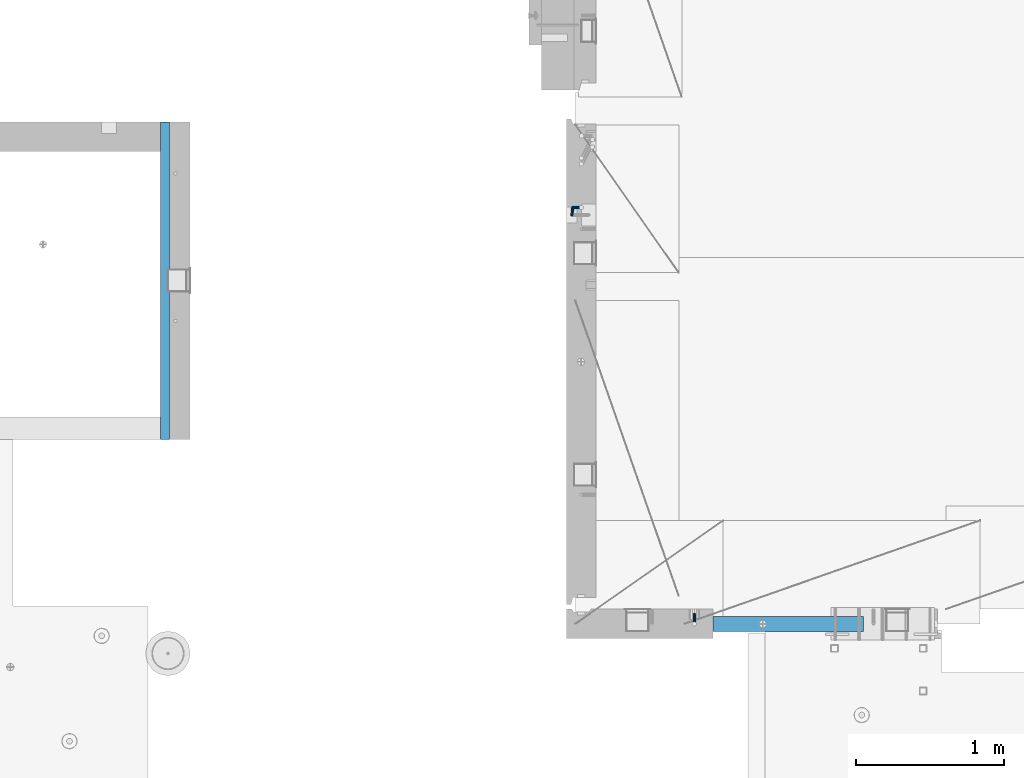
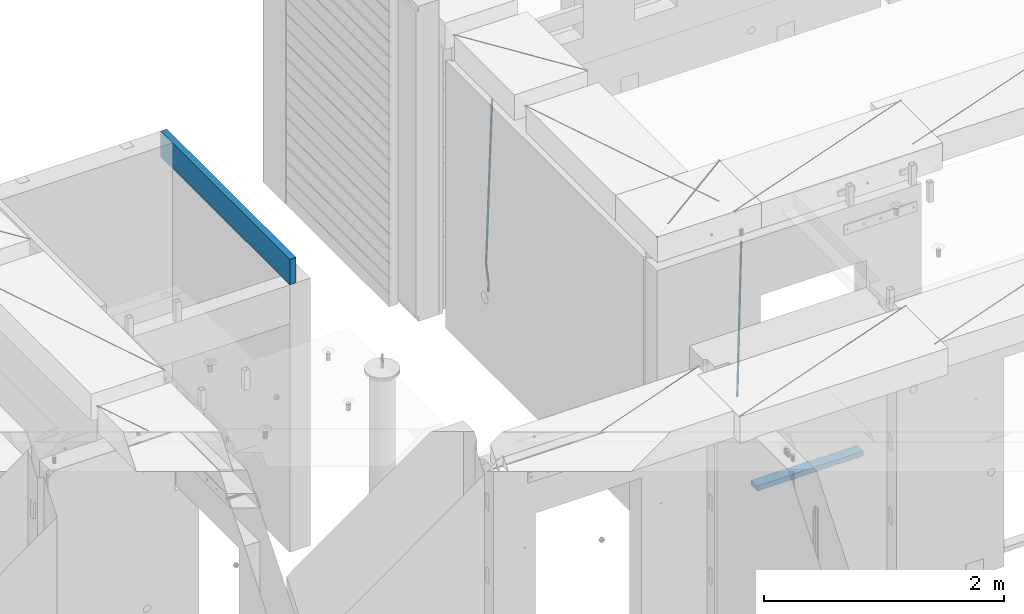
# One storey, part 102 of 309: 4 beams, 3 elements without a shape of their own.
"""IFC2X3 building model written with IfcOpenShell, lengths in millimetres."""

from ifc_helpers import new_model, si_unit, frame, origin_with_axes, place, context, subcontext, project, spatial, faceted_brep, material, type_object, element, aggregate, save


model = new_model("IFC2X3")

# Units and contexts
model_context = context("Model", 3, precision=1e-05, world=origin_with_axes())
body_context = subcontext(model_context, "Body", "Model", "MODEL_VIEW")
ifc_project = project(units=[si_unit("LENGTHUNIT", "METRE", prefix="MILLI"), si_unit("AREAUNIT", "SQUARE_METRE"), si_unit("VOLUMEUNIT", "CUBIC_METRE"), si_unit("MASSUNIT", "GRAM", prefix="KILO"), si_unit("TIMEUNIT", "SECOND"), si_unit("PLANEANGLEUNIT", "RADIAN"), si_unit("SOLIDANGLEUNIT", "STERADIAN"), si_unit("THERMODYNAMICTEMPERATUREUNIT", "DEGREE_CELSIUS"), si_unit("LUMINOUSINTENSITYUNIT", "LUMEN")], contexts=[model_context])

# Site, building, storey
site_placement = place(None, origin_with_axes())
site = spatial("IfcSite", under=ifc_project, at=site_placement, CompositionType="ELEMENT")
building_placement = place(site_placement, origin_with_axes())
building = spatial("IfcBuilding", under=site, at=building_placement, CompositionType="ELEMENT")
storey_placement = place(building_placement, origin_with_axes())
storey = spatial("IfcBuildingStorey", under=building, at=storey_placement, Name="7", CompositionType="ELEMENT", Elevation=0.0)

# Assembly, beam
assembly_1_placement = place(storey_placement, origin_with_axes())
assembly_1 = element("IfcElementAssembly", 1, at=assembly_1_placement, inside=storey, Name="W1", AssemblyPlace="NOTDEFINED", PredefinedType="REINFORCEMENT_UNIT")
ifc_material_1 = material()
beam_type_1 = type_object("IfcBeamType", Name="D20", PredefinedType="NOTDEFINED")
beam_1_placement = place(assembly_1_placement, frame((22244.9999977209, 19749.9999999961, 100510.0), z_axis=(0.999839490204639, 0.000205763000043867, -0.0179151190036643), x_axis=(0.0179151190067552, -2.89999975377855e-08, 0.999839511377188)))
beam_1 = element("IfcBeam", 2, at=beam_1_placement, type_object=beam_type_1, material=ifc_material_1, Name="JM20", ObjectType="D20", context=body_context, shape_type="Brep", body=[
    faceted_brep([(0.0, -10.0, 0.0), (-4.19531716033816e-08, -7.07106781186667, -7.07106781187031), (89.0110247484263, -7.07106781240145, -7.07106781090988), (89.0110247510165, -10.0000000005348, 9.56788426265121e-10), (0.0, 0.0, -10.0), (89.011024747364, -5.3114490583539e-10, -9.99999999903957), (4.196772351861e-08, 7.07106781186303, -7.07106781186667), (89.011024748499, 7.07106781132825, -7.07106781090988), (0.0, 10.0, 0.0), (89.0110247511475, 9.99999999946522, 9.60426405072212e-10), (4.196772351861e-08, 7.07106781185939, 7.07106781185939), (89.0110247537523, 7.07106781133189, 7.07106781282346), (0.0, 0.0, 10.0), (89.0110247548, -5.38420863449574e-10, 10.0000000009604), (-4.19531716033816e-08, -7.07106781187031, 7.07106781185939), (89.011024753665, -7.07106781240145, 7.07106781282346), (89.976954074853, -7.07106781240873, -7.07106781089533), (89.5110247510311, -10.0000000005384, 9.64064383879304e-10), (91.0331505986251, -5.45696821063757e-10, -9.99999999902502), (92.0609087232588, 7.0710678113137, -7.0710678108735), (92.4581816781865, 9.99999999944339, 9.96806193143129e-10), (91.9922523543646, 7.0710678113137, 7.0710678128562), (90.9360558305925, -5.49334799870849e-10, 10.0000000009786), (89.9082977059443, -7.07106781240509, 7.07106781283073), (90.9017822964088, -7.34968577266045, -7.06188867690798), (89.9897493307071, -10.1442227467705, 0.00475145313612302), (92.9692332949489, -0.583273087540874, -9.98078393048854), (94.9810175709281, 6.19134252624281, -7.04208505521092), (95.7586591800355, 9.00568312201358, 0.0327580035191204), (94.8466262143338, 6.21114614789622, 7.09939813356323), (92.7791752157791, -0.555266537216085, 10.0182933871438), (90.7673909398, -7.3298821510034, 7.07959451186616), (253.08880553169, -56.210886739078, -5.45214496144763), (252.176772565959, -59.0054237131953, 1.61449516859284), (255.15625653023, -49.4444740539693, -8.37104021503183), (257.168040806209, -42.6698584401747, -5.43234133975056), (257.945682415317, -39.8555178444112, 1.64250171897947), (257.033649449615, -42.6500548185213, 8.70914184901994), (254.966198451046, -49.4164675036409, 11.6280371026041), (252.954414175081, -56.1910831174246, 8.68933822732652), (256.040808205085, -57.1002205032819, -5.4228456521887), (255.476727913934, -59.9995832841632, 1.64724798862153), (257.137813126028, -50.0414468149283, -8.35137280753406), (258.125132072062, -42.9581961120275, -5.42284198758716), (258.424406994978, -39.9997405906397, 1.6472531711479), (257.860326703827, -42.8991033715283, 8.71734681195812), (256.763321782899, -49.9578770598782, 11.6458739673035), (255.77600283685, -57.0411277627827, 8.71734314736023), (259.122763950654, -57.1002024144545, -5.33542963766376), (258.921953907935, -59.9995630632038, 1.74496773231294), (259.206601813319, -50.0414346726539, -8.2926940733596), (259.124356413013, -42.958190247311, -5.39450017585841), (258.924205989781, -39.9997376571882, 1.66142937606492), (258.723395947076, -42.8990983059412, 8.74182674604526), (258.639558084411, -49.9578660477418, 11.6990911817338), (258.721803484717, -57.0411104730847, 8.80089728423263), (379.553966330364, -57.0994955712195, -1.91954160900059), (379.353156287645, -59.9988562199724, 5.16085576097976), (379.637804193029, -50.0407278294188, -4.87680604468915), (379.555558792737, -42.9574834040832, -1.9786121471916), (379.355408369505, -39.9990308139568, 5.07731740473173), (379.154598326786, -42.8983914627097, 12.1577147747084), (379.070760464136, -49.9571592045104, 15.1149792104006), (379.153005864428, -57.0404036298532, 12.2167853129031), (380.071125123432, -57.0994925358791, -1.90487301402027), (379.911895631682, -59.9988529405782, 5.17670373889996), (380.137603187861, -50.0407248959636, -4.86262983977576), (380.07238787644, -42.957480370671, -1.96395290403234), (379.913681434104, -39.9990275372984, 5.09315215719107), (379.754451942368, -42.8983879420121, 12.1747289101186), (379.687973877939, -49.9571555819202, 15.1324857358704), (379.75318918936, -57.0404001072166, 12.2338088001234), (380.588420535452, -57.0994907600943, -1.89627990118606), (380.470782579127, -59.9988510220282, 5.18598775436112), (380.637534215668, -50.0407231797944, -4.85432517742447), (380.589353492032, -42.9574785960249, -1.95536526964497), (380.472101978958, -39.9990256203491, 5.10242842495063), (380.354464022632, -42.898385882283, 12.1846960805015), (380.305350342416, -49.9571534625793, 15.1427413567362), (380.353531066052, -57.0403980463561, 12.2437814489567), (1774.34333976687, -57.0947062606101, 21.2562418682064), (1774.22570181053, -59.994066522544, 28.3385095237536), (1774.39245344709, -50.0359386803066, 18.298196591968), (1774.34427272342, -42.952694096537, 21.1971564997511), (1774.22702121038, -39.9942411208649, 28.2549501943431), (1774.10938325404, -42.8936013827915, 35.3372178498939), (1774.06026957383, -49.9523689630987, 38.2952631261323), (1774.10845029748, -57.0356135468646, 35.3963032183528), (1774.88184095189, -57.0947044120367, 21.265187243207), (1774.72579033222, -59.9940648058328, 28.3468168023355), (1774.9851208477, -50.0359366457924, 18.3080417553501), (1774.97513005743, -42.952691930921, 21.2076360596475), (1774.85772105052, -39.9942389557873, 28.2654271380125), (1774.70167043086, -42.8935993495834, 35.3470566971446), (1774.59839053503, -49.9523671158277, 38.3042021849978), (1774.60838132531, -57.0356118306954, 35.4046078807005), (1775.42023891953, -57.1017252492275, 21.2770986786563), (1775.22578299929, -60.0005848287947, 28.3578785647078), (1775.57767464862, -50.0436636878912, 18.3211513262904), (1775.60586647167, -42.9609168833595, 21.2215903769684), (1775.48830000107, -40.0024618548559, 28.2793779716303), (1775.29384408084, -42.9013214344195, 35.3601578576818), (1775.13640835174, -49.9593829957594, 38.3161052100477), (1775.10821652869, -57.0421298002984, 35.4156661593697), (1797.25780408196, -57.3864922781577, 21.7602296774785), (1797.06334816174, -60.2853518577213, 28.841009563519), (1797.41523981106, -50.3284307168215, 18.8042823251126), (1797.44343163411, -43.2456839122824, 21.7047213757796), (1797.32586516351, -40.2872288837862, 28.7625089704488), (1797.13140924327, -43.1860884633497, 35.8432888564967), (1796.97397351419, -50.244150024686, 38.7992362088589), (1796.94578169113, -57.3268968292286, 35.8987971581882), (1797.8933907514, -57.394780479066, 21.7742913011098), (1797.72334564425, -60.2939583814259, 28.8556112483093), (1797.9938047452, -50.3359753407822, 18.8170824084737), (1797.96576646989, -43.2524952824278, 21.7162774329299), (1797.82570036691, -40.2937468533892, 28.7735672491181), (1797.65565525973, -43.1929247557455, 35.8548871963139), (1797.55524126595, -50.2517298940293, 38.8120960889537), (1797.58327954126, -57.3352099523836, 35.9129010644974), (1798.52903302865, -57.3928987848594, 21.7881546696226), (1798.38340069888, -60.291988491208, 28.8700127493285), (1798.57242062438, -50.3342702388327, 18.8296881194801), (1798.48814762091, -43.2509517236358, 21.7276426801363), (1798.32558000075, -40.2922551588599, 28.7844358731018), (1798.17994767097, -43.1913448652049, 35.8662939528003), (1798.13656007525, -50.2499734112316, 38.8247605029428), (1798.22083307871, -57.3332919264358, 35.9268059422866), (1898.53449695595, -57.0944531984715, 23.9668554182972), (1898.38886462618, -59.9935429048164, 31.0487134979994), (1898.57788455166, -50.0358246524411, 21.0083888681547), (1898.49361154821, -42.9525061372478, 23.9063434288073), (1898.33104392805, -39.9938095724719, 30.9631366217764), (1898.18541159826, -42.8928992788169, 38.0449947014749), (1898.14202400253, -49.95152782484, 41.0034612516174), (1898.22629700601, -57.0348463400442, 38.1055066909612)], [[[0, 1, 2, 3]], [[1, 4, 5, 2]], [[4, 6, 7, 5]], [[6, 8, 9, 7]], [[8, 10, 11, 9]], [[10, 12, 13, 11]], [[12, 14, 15, 13]], [[14, 0, 3, 15]], [[14, 12, 10, 8, 6, 4, 1, 0]], [[3, 2, 16, 17]], [[2, 5, 18, 16]], [[5, 7, 19, 18]], [[7, 9, 20, 19]], [[9, 11, 21, 20]], [[11, 13, 22, 21]], [[13, 15, 23, 22]], [[15, 3, 17, 23]], [[17, 16, 24, 25]], [[16, 18, 26, 24]], [[18, 19, 27, 26]], [[19, 20, 28, 27]], [[20, 21, 29, 28]], [[21, 22, 30, 29]], [[22, 23, 31, 30]], [[23, 17, 25, 31]], [[25, 24, 32, 33]], [[24, 26, 34, 32]], [[26, 27, 35, 34]], [[27, 28, 36, 35]], [[28, 29, 37, 36]], [[29, 30, 38, 37]], [[30, 31, 39, 38]], [[31, 25, 33, 39]], [[33, 32, 40, 41]], [[32, 34, 42, 40]], [[34, 35, 43, 42]], [[35, 36, 44, 43]], [[36, 37, 45, 44]], [[37, 38, 46, 45]], [[38, 39, 47, 46]], [[39, 33, 41, 47]], [[41, 40, 48, 49]], [[40, 42, 50, 48]], [[42, 43, 51, 50]], [[43, 44, 52, 51]], [[44, 45, 53, 52]], [[45, 46, 54, 53]], [[46, 47, 55, 54]], [[47, 41, 49, 55]], [[49, 48, 56, 57]], [[48, 50, 58, 56]], [[50, 51, 59, 58]], [[51, 52, 60, 59]], [[52, 53, 61, 60]], [[53, 54, 62, 61]], [[54, 55, 63, 62]], [[55, 49, 57, 63]], [[57, 56, 64, 65]], [[56, 58, 66, 64]], [[58, 59, 67, 66]], [[59, 60, 68, 67]], [[60, 61, 69, 68]], [[61, 62, 70, 69]], [[62, 63, 71, 70]], [[63, 57, 65, 71]], [[65, 64, 72, 73]], [[64, 66, 74, 72]], [[66, 67, 75, 74]], [[67, 68, 76, 75]], [[68, 69, 77, 76]], [[69, 70, 78, 77]], [[70, 71, 79, 78]], [[71, 65, 73, 79]], [[73, 72, 80, 81]], [[72, 74, 82, 80]], [[74, 75, 83, 82]], [[75, 76, 84, 83]], [[76, 77, 85, 84]], [[77, 78, 86, 85]], [[78, 79, 87, 86]], [[79, 73, 81, 87]], [[81, 80, 88, 89]], [[80, 82, 90, 88]], [[82, 83, 91, 90]], [[83, 84, 92, 91]], [[84, 85, 93, 92]], [[85, 86, 94, 93]], [[86, 87, 95, 94]], [[87, 81, 89, 95]], [[89, 88, 96, 97]], [[88, 90, 98, 96]], [[90, 91, 99, 98]], [[91, 92, 100, 99]], [[92, 93, 101, 100]], [[93, 94, 102, 101]], [[94, 95, 103, 102]], [[95, 89, 97, 103]], [[97, 96, 104, 105]], [[96, 98, 106, 104]], [[98, 99, 107, 106]], [[99, 100, 108, 107]], [[100, 101, 109, 108]], [[101, 102, 110, 109]], [[102, 103, 111, 110]], [[103, 97, 105, 111]], [[105, 104, 112, 113]], [[104, 106, 114, 112]], [[106, 107, 115, 114]], [[107, 108, 116, 115]], [[108, 109, 117, 116]], [[109, 110, 118, 117]], [[110, 111, 119, 118]], [[111, 105, 113, 119]], [[113, 112, 120, 121]], [[112, 114, 122, 120]], [[114, 115, 123, 122]], [[115, 116, 124, 123]], [[116, 117, 125, 124]], [[117, 118, 126, 125]], [[118, 119, 127, 126]], [[119, 113, 121, 127]], [[121, 120, 128, 129]], [[120, 122, 130, 128]], [[122, 123, 131, 130]], [[123, 124, 132, 131]], [[124, 125, 133, 132]], [[125, 126, 134, 133]], [[126, 127, 135, 134]], [[127, 121, 129, 135]], [[130, 131, 132, 133, 134, 135, 129, 128]]]),
])
aggregate(assembly_1, [beam_1])

assembly_2_placement = place(storey_placement, origin_with_axes())
assembly_2 = element("IfcElementAssembly", 3, at=assembly_2_placement, inside=storey, AssemblyPlace="NOTDEFINED", PredefinedType="REINFORCEMENT_UNIT")
beam_2_placement = place(assembly_2_placement, frame((23075.0006866416, 17045.0000022791, 100790.0), z_axis=(0.00020576299992186, -0.999642804629538, -0.0267249099901004), x_axis=(-4.30000201928125e-08, -0.0267249099948059, 0.999642825806181)))
beam_2 = element("IfcBeam", 4, at=beam_2_placement, type_object=beam_type_1, material=ifc_material_1, Name="JM20", ObjectType="D20", context=body_context, shape_type="Brep", body=[
    faceted_brep([(0.0, -10.0, 0.0), (-4.19531716033816e-08, -7.07106781186667, -7.07106781187031), (60.4266690400545, -7.0710677960451, -7.07106780570757), (60.4266690441291, -9.99999998418934, 6.15546014159918e-09), (0.0, 0.0, -10.0), (60.426669036824, 1.58106558956206e-08, -9.99999999384454), (4.196772351861e-08, 7.07106781186303, -7.07106781186667), (60.4266690363438, 7.07106782768096, -7.07106780570757), (0.0, 10.0, 0.0), (60.4266690388904, 10.0000000158179, 6.15182216279209e-09), (4.196772351861e-08, 7.07106781185939, 7.07106781185939), (60.4266690429649, 7.07106782768096, 7.07106781802577), (0.0, 0.0, 10.0), (60.4266690461809, 1.58179318532348e-08, 10.0000000061555), (-4.19531716033816e-08, -7.07106781187031, 7.07106781185939), (60.4266690466611, -7.07106779605238, 7.07106781802213), (61.0378400410118, -7.07106779588503, -7.07106780564936), (60.991799419251, -9.99999998403655, 6.21366780251265e-09), (61.0569027789461, 1.5985278878361e-08, -9.99999999378269), (61.0378209396877, 7.07106782784831, -7.07106780564936), (60.9917724058905, 10.0000000159635, 6.21366780251265e-09), (60.9457317841297, 7.07106782781193, 7.0710678180767), (60.9266690461809, 1.59488990902901e-08, 10.0000000062028), (60.9457508854539, -7.07106779591413, 7.0710678180767), (61.6489592143771, -7.07106614513759, -7.06310863441468), (61.5568818710308, -9.9999984576425, 0.00735959856683621), (61.6870830769039, 1.71821739058942e-06, -9.99179257185824), (61.6489210170112, 7.07106947854481, -7.06310888312146), (61.556827851804, 10.0000015422847, 0.00735924683976918), (61.4647505084577, 7.07106922979438, 7.07782747982128), (61.4266266459163, 1.36643211590126e-06, 10.0065114172685), (61.464788705809, -7.07106639389531, 7.07782772852806), (176.543135720174, -7.07075579406956, -5.56673531796696), (176.451058376813, -9.99968810657447, 1.50373291501455), (176.581259582701, 0.000312069292704109, -8.49541925541052), (176.543097522794, 7.07137982961285, -5.56673556667374), (176.451004357587, 10.00031189336, 1.50373256329476), (176.35892701424, 7.07137958085514, 8.57420079627263), (176.320803151699, 0.000311717507429421, 11.5028847337162), (176.358965211621, -7.07075604281999, 8.57420104497578), (177.098753836006, -7.07075429323595, -5.55949898843028), (176.98362511232, -9.99968666800123, 1.510669025065), (177.146421932586, 0.000313595905026887, -8.48805862247536), (177.098706077581, 7.07138133041735, -5.55949936166144), (176.983557571715, 10.0003133318824, 1.51066849724157), (176.868428848029, 7.07138095712435, 8.58083651073321), (176.820760751449, 0.000313067976094317, 11.5093961447819), (176.868476606425, -7.07075466652896, 8.58083688396073), (177.654312950661, -7.07075204110879, -5.54863964998367), (177.516135294456, -9.99968450931192, 1.52107783331303), (177.711524267797, 0.000315886711177882, -8.47701274570863), (177.654255632195, 7.07138358250813, -5.54864021007961), (177.516054233929, 10.0003154905207, 1.5210770412159), (177.377876577739, 7.0713830223176, 8.59079452451624), (177.320665260588, 0.000315094497636892, 11.5191676202448), (177.377933896176, -7.07075260129932, 8.59079508461218), (299.580241614967, -7.07025777803938, -3.16539205229128), (299.442063958748, -9.99919024624614, 3.90432543100542), (299.637452932104, 0.000810149780591019, -6.09376514801625), (299.58018429653, 7.07187784557391, -3.16539261238358), (299.441982898265, 10.0008097535901, 3.90432463891557), (299.303805242045, 7.07187728538338, 10.974042122205), (299.246593924894, 0.00080935756341205, 13.9024152179336), (299.303862560482, -7.07025833822991, 10.9740426822973), (300.088882651282, -7.07025571611666, -3.15544980669438), (299.971788958996, -9.99918809853989, 3.91467979818117), (300.137357441272, 0.000812176291219657, -6.0839936725497), (300.088834180511, 7.07187990754028, -3.15545019384081), (299.971753863239, 10.0008119014747, 3.91467990454839), (299.854660170953, 7.07187951844026, 10.9848095094276), (299.806185380992, 0.000811626032373169, 13.9133533752902), (299.854708641738, -7.07025610520941, 10.9848098965813), (300.597573977022, -7.07025429077839, -3.14854421417112), (300.501599787152, -9.99918661431002, 3.92187219230618), (300.637311376035, 0.00081357714952901, -6.07720669196715), (300.597534354776, 7.07188133290401, -3.14854448120241), (300.501543752835, 10.0008133856099, 3.92187181466215), (300.40556956298, 7.07188106207104, 10.9922882211395), (300.365832163967, 0.000813194146758178, 13.9209506989318), (300.405609185211, -7.07025456160045, 10.9922884881707), (1494.60304651056, -7.06690872122999, 13.060333041718), (1494.50707232069, -9.99584104476162, 20.1307494481916), (1494.64278390956, 0.00415914670156781, 10.1316705639183), (1494.6030068883, 7.07522690244878, 13.0603327746867), (1494.50701628637, 10.004158955162, 20.1307490705476), (1494.4110420965, 7.07522663162308, 27.2011654770249), (1494.3713046975, 0.00415876370243495, 30.1298279548209), (1494.41108171875, -7.06690899205205, 27.2011657440526), (1495.1211563645, -7.06690726950183, 13.067366492749), (1495.00702625545, -9.99583964390331, 20.1375364287742), (1495.20660775043, 0.00416072652296862, 10.1393245920117), (1495.21332415029, 7.07522861253892, 13.0686179608165), (1495.13737118813, 10.0041607213934, 20.1393062718889), (1495.02324107911, 7.07522834699193, 27.2094762079141), (1494.93778969315, 0.00416035097441636, 30.1375181086514), (1494.93107329329, -7.06690753504881, 27.2082247398503), (1495.63922435709, -7.07365070849846, 13.0742491942874), (1495.5069397148, -10.00235861486, 20.1441724282631), (1495.77038591086, -0.00317370150150964, 10.1468279224828), (1495.82359171678, 7.06728286786529, 13.0767522910828), (1495.76767453534, 9.99594143344802, 20.1477123416917), (1495.63538989302, 7.0672335270865, 27.2176355756565), (1495.50422833927, -0.00324347991045215, 30.1450568474684), (1495.45102253335, -7.07370004928453, 27.2151324788683), (1517.48046966468, -7.35846502584536, 13.3649345949125), (1517.34818502239, -10.2871729322142, 20.4348578288809), (1517.61163121845, -0.287988018848409, 10.4375133231042), (1517.66483702436, 6.78246855052203, 13.3674376917079), (1517.60891984291, 9.71112711610476, 20.4383977423167), (1517.47663520063, 6.78241920973232, 27.5083209762815), (1517.34547364687, -0.288057797257352, 30.4357422480862), (1517.29226784095, -7.35851436663143, 27.5058178794898), (1518.11590717161, -7.36675126123009, 13.3733916404526), (1518.00827439407, -10.295780632965, 20.4436429663911), (1518.18994308249, -0.295529324139352, 10.4452100827657), (1518.18701289421, 6.77565927010801, 13.3743873367348), (1518.10883307132, 9.70460814510079, 20.4450510935785), (1518.00120029377, 6.77557877335857, 27.515302419517), (1517.9271643829, -0.295643163732166, 30.4434839772002), (1517.93009457119, -7.36683175797953, 27.5143067232275), (1518.75139849893, -7.36487536471395, 13.3816537936873), (1518.66841952164, -10.2938120781764, 20.4522328350286), (1518.76830418318, -0.293831718903675, 10.452712053142), (1518.7092334538, 6.77719739167878, 13.3811419616068), (1518.60878914295, 9.7060990139762, 20.4515089951637), (1518.52581016565, 6.77716230052101, 27.522088036505), (1518.50890448141, -0.293881345296541, 30.4510297770539), (1518.56797521077, -7.36491045587172, 27.5225998685855), (1618.77218426704, -7.06661321754655, 14.6790318180938), (1618.68920528975, -9.99554993101265, 21.7496108594387), (1618.78908995127, 0.0044304282637313, 11.7500900775485), (1618.73001922191, 7.07545953884255, 14.6785199860096), (1618.62957491104, 10.0043611611436, 21.748887019563), (1618.54659593375, 7.07542444768478, 28.8194660609042), (1618.52969024952, 0.00438080187086598, 31.7484078014531), (1618.58876097888, -7.06664830870795, 28.819977892992)], [[[0, 1, 2, 3]], [[1, 4, 5, 2]], [[4, 6, 7, 5]], [[6, 8, 9, 7]], [[8, 10, 11, 9]], [[10, 12, 13, 11]], [[12, 14, 15, 13]], [[14, 0, 3, 15]], [[14, 12, 10, 8, 6, 4, 1, 0]], [[3, 2, 16, 17]], [[2, 5, 18, 16]], [[5, 7, 19, 18]], [[7, 9, 20, 19]], [[9, 11, 21, 20]], [[11, 13, 22, 21]], [[13, 15, 23, 22]], [[15, 3, 17, 23]], [[17, 16, 24, 25]], [[16, 18, 26, 24]], [[18, 19, 27, 26]], [[19, 20, 28, 27]], [[20, 21, 29, 28]], [[21, 22, 30, 29]], [[22, 23, 31, 30]], [[23, 17, 25, 31]], [[25, 24, 32, 33]], [[24, 26, 34, 32]], [[26, 27, 35, 34]], [[27, 28, 36, 35]], [[28, 29, 37, 36]], [[29, 30, 38, 37]], [[30, 31, 39, 38]], [[31, 25, 33, 39]], [[33, 32, 40, 41]], [[32, 34, 42, 40]], [[34, 35, 43, 42]], [[35, 36, 44, 43]], [[36, 37, 45, 44]], [[37, 38, 46, 45]], [[38, 39, 47, 46]], [[39, 33, 41, 47]], [[41, 40, 48, 49]], [[40, 42, 50, 48]], [[42, 43, 51, 50]], [[43, 44, 52, 51]], [[44, 45, 53, 52]], [[45, 46, 54, 53]], [[46, 47, 55, 54]], [[47, 41, 49, 55]], [[49, 48, 56, 57]], [[48, 50, 58, 56]], [[50, 51, 59, 58]], [[51, 52, 60, 59]], [[52, 53, 61, 60]], [[53, 54, 62, 61]], [[54, 55, 63, 62]], [[55, 49, 57, 63]], [[57, 56, 64, 65]], [[56, 58, 66, 64]], [[58, 59, 67, 66]], [[59, 60, 68, 67]], [[60, 61, 69, 68]], [[61, 62, 70, 69]], [[62, 63, 71, 70]], [[63, 57, 65, 71]], [[65, 64, 72, 73]], [[64, 66, 74, 72]], [[66, 67, 75, 74]], [[67, 68, 76, 75]], [[68, 69, 77, 76]], [[69, 70, 78, 77]], [[70, 71, 79, 78]], [[71, 65, 73, 79]], [[73, 72, 80, 81]], [[72, 74, 82, 80]], [[74, 75, 83, 82]], [[75, 76, 84, 83]], [[76, 77, 85, 84]], [[77, 78, 86, 85]], [[78, 79, 87, 86]], [[79, 73, 81, 87]], [[81, 80, 88, 89]], [[80, 82, 90, 88]], [[82, 83, 91, 90]], [[83, 84, 92, 91]], [[84, 85, 93, 92]], [[85, 86, 94, 93]], [[86, 87, 95, 94]], [[87, 81, 89, 95]], [[89, 88, 96, 97]], [[88, 90, 98, 96]], [[90, 91, 99, 98]], [[91, 92, 100, 99]], [[92, 93, 101, 100]], [[93, 94, 102, 101]], [[94, 95, 103, 102]], [[95, 89, 97, 103]], [[97, 96, 104, 105]], [[96, 98, 106, 104]], [[98, 99, 107, 106]], [[99, 100, 108, 107]], [[100, 101, 109, 108]], [[101, 102, 110, 109]], [[102, 103, 111, 110]], [[103, 97, 105, 111]], [[105, 104, 112, 113]], [[104, 106, 114, 112]], [[106, 107, 115, 114]], [[107, 108, 116, 115]], [[108, 109, 117, 116]], [[109, 110, 118, 117]], [[110, 111, 119, 118]], [[111, 105, 113, 119]], [[113, 112, 120, 121]], [[112, 114, 122, 120]], [[114, 115, 123, 122]], [[115, 116, 124, 123]], [[116, 117, 125, 124]], [[117, 118, 126, 125]], [[118, 119, 127, 126]], [[119, 113, 121, 127]], [[121, 120, 128, 129]], [[120, 122, 130, 128]], [[122, 123, 131, 130]], [[123, 124, 132, 131]], [[124, 125, 133, 132]], [[125, 126, 134, 133]], [[126, 127, 135, 134]], [[127, 121, 129, 135]], [[130, 131, 132, 133, 134, 135, 129, 128]]]),
])

assembly_3_placement = place(storey_placement, origin_with_axes())
assembly_3 = element("IfcElementAssembly", 5, at=assembly_3_placement, inside=storey, AssemblyPlace="NOTDEFINED", PredefinedType="REINFORCEMENT_UNIT")
ifc_material_2 = material(Name="CONCRETE/C25/30")
beam_type_2 = type_object("IfcBeamType", Name="260X60", PredefinedType="NOTDEFINED")
beam_3_placement = place(assembly_3_placement, frame((19489.999681647, 20380.0, 102600.0), z_axis=(0.0, 0.0, 1.0), x_axis=(0.0, -1.0, 0.0)))
beam_3 = element("IfcBeam", 6, at=beam_3_placement, type_object=beam_type_2, material=ifc_material_2, ObjectType="260X60", context=body_context, shape_type="Brep", body=[
    faceted_brep([(0.0, 30.0, -130.0), (0.0, 30.0, 130.0), (2150.00073363433, 30.0, 130.0), (2150.00073363433, 30.0, -130.0), (0.0, -30.0, 130.0), (2150.00073363433, -30.0, 130.0), (0.0, -30.0, -130.0), (2150.00073363433, -30.0, -130.0)], [[[0, 1, 2, 3]], [[1, 4, 5, 2]], [[4, 6, 7, 5]], [[6, 0, 3, 7]], [[5, 7, 3, 2]], [[6, 4, 1, 0]]]),
])
aggregate(assembly_3, [beam_3])

# Beam
ifc_material_3 = material(Name="TIMBER/T24")
beam_type_3 = type_object("IfcBeamType", PredefinedType="NOTDEFINED")
beam_4_placement = place(assembly_2_placement, frame((23200.0006866455, 16980.0, 99880.0), z_axis=(0.0, 0.0, 1.0), x_axis=(1.0, 0.0, 0.0)))
beam_4 = element("IfcBeam", 7, at=beam_4_placement, type_object=beam_type_3, material=ifc_material_3, context=body_context, shape_type="Brep", body=[
    faceted_brep([(0.0, 50.0, -25.0), (0.0, 50.0, 25.0), (1020.0, 50.0, 25.0), (1020.0, 50.0, -25.0), (0.0, -50.0, 25.0), (1020.0, -50.0, 25.0), (0.0, -50.0, -25.0), (1020.0, -50.0, -25.0)], [[[0, 1, 2, 3]], [[1, 4, 5, 2]], [[4, 6, 7, 5]], [[6, 0, 3, 7]], [[5, 7, 3, 2]], [[6, 4, 1, 0]]]),
])

aggregate(assembly_2, [beam_2, beam_4])

save(model, "model.ifc")
